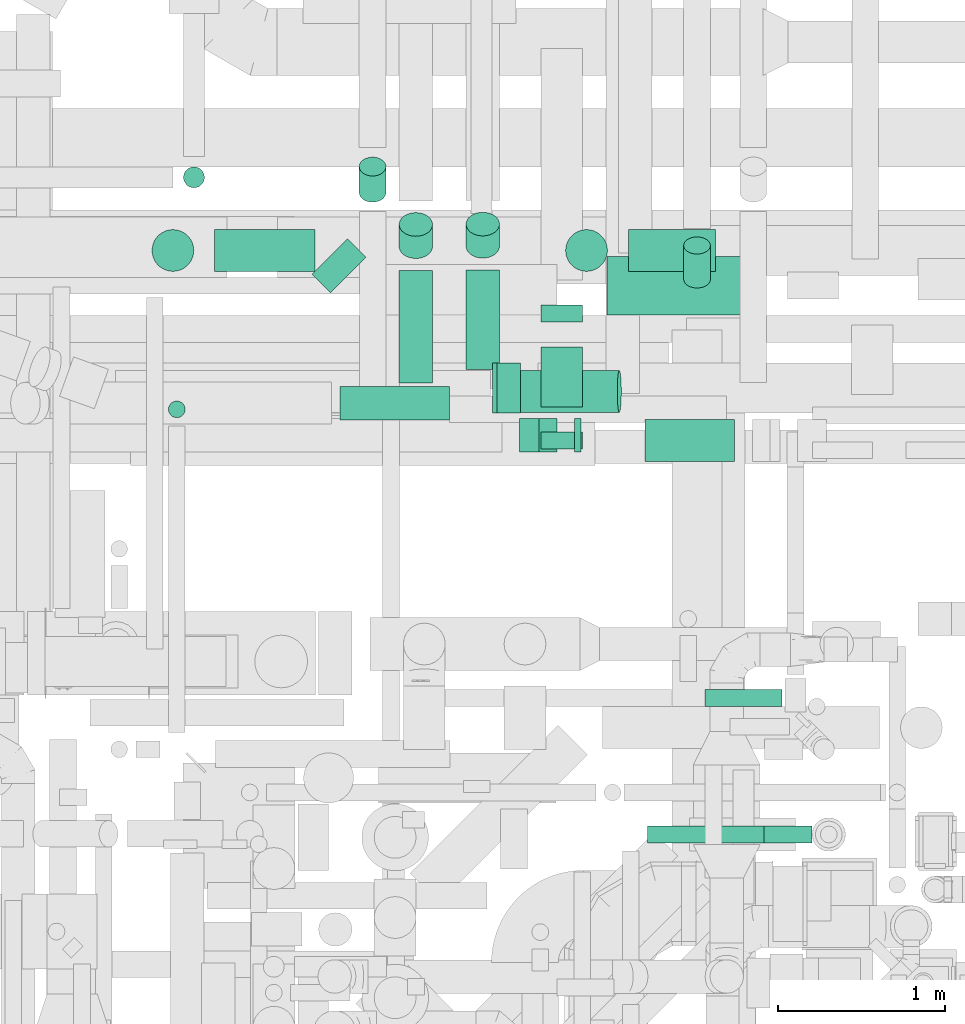
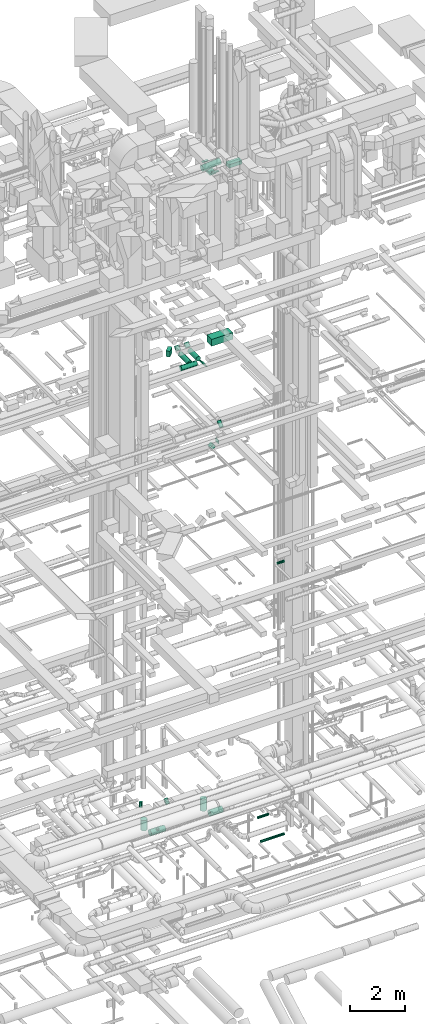
# One storey, part 248 of 337: 26 flow segments.
"""IFC2X3 building model written with IfcOpenShell, lengths in millimetres."""

import ifcopenshell
import ifcopenshell.guid

model = None  # the IFC model being written
_history = None  # IfcOwnerHistory: only IFC2X3 demands one
_inside = {}  # id of a spatial element -> (the spatial element, [elements in it])
_under = {}  # id of a project, library or spatial element -> (it, [spatial elements below it])
_declared = {}  # id of a project -> (the project, [libraries it declares])
_typed = {}  # id of a type object -> (the type object, [elements of that type])
_made_of = {}  # id of a material, layer set ... -> (it, [elements and type objects made of it])


def new_model(schema):
    """Start an empty IFC model of exactly this schema.

    Asked for "IFC4X3", IfcOpenShell would pick the latest addendum, in which some entities
    have other attributes; the version numbers below select the first issue.
    IFC2X3 requires an IfcOwnerHistory on every rooted entity: one is made here for all.
    """
    global model, _history
    if schema == "IFC4X3":
        model = ifcopenshell.file(schema_version=(4, 3, 0, 0))
    else:
        model = ifcopenshell.file(schema=schema)
    _inside.clear()
    _under.clear()
    _declared.clear()
    _typed.clear()
    _made_of.clear()
    _history = None
    if model.schema == "IFC2X3":
        org = make("IfcOrganization", Name="unknown")
        user = make(
            "IfcPersonAndOrganization",
            ThePerson=make("IfcPerson", FamilyName="unknown"),
            TheOrganization=org,
        )
        app = make(
            "IfcApplication",
            ApplicationDeveloper=org,
            Version="unknown",
            ApplicationFullName="unknown",
            ApplicationIdentifier="unknown",
        )
        _history = make(
            "IfcOwnerHistory",
            OwningUser=user,
            OwningApplication=app,
            ChangeAction="ADDED",
            CreationDate=0,
        )
    return model


def make(cls, **values):
    """One entity of the class cls with the attributes given. An attribute that is None is left unset."""
    return model.create_entity(
        cls, **{name: value for name, value in values.items() if value is not None}
    )


def entity(cls, *values):
    """Any entity or typed value of the class cls, its attributes in the order of the schema. None: left unset."""
    e = model.create_entity(cls)
    for i, value in enumerate(values):
        if value is not None:
            e[i] = value
    return e


def rooted(cls, **values):
    """An entity with a GlobalId (a new one), such as an element, a storey or a relation."""
    return make(cls, GlobalId=ifcopenshell.guid.new(), OwnerHistory=_history, **values)


def si_unit(unit_type, name, prefix=None):
    """IfcSIUnit, for example si_unit("LENGTHUNIT", "METRE", prefix="MILLI")."""
    return make("IfcSIUnit", UnitType=unit_type, Prefix=prefix, Name=name)


def converted_unit(unit_type, name, factor, base, dimensions=None, offset=None):
    """IfcConversionBasedUnit, such as the inch: factor (a typed value) times the base unit."""
    return make(
        "IfcConversionBasedUnit"
        if offset is None
        else "IfcConversionBasedUnitWithOffset",
        ConversionOffset=offset,
        Dimensions=None
        if dimensions is None
        else entity("IfcDimensionalExponents", *dimensions),
        UnitType=unit_type,
        Name=name,
        ConversionFactor=make(
            "IfcMeasureWithUnit", ValueComponent=factor, UnitComponent=base
        ),
    )


def derived_unit(unit_type, elements):
    """IfcDerivedUnit: a product of units, each with its exponent."""
    return make(
        "IfcDerivedUnit",
        Elements=[
            make("IfcDerivedUnitElement", Unit=unit, Exponent=power)
            for unit, power in elements
        ],
        UnitType=unit_type,
    )


def assignment(units):
    """IfcUnitAssignment: the units of a project."""
    return None if units is None else make("IfcUnitAssignment", Units=units)


def point(xyz):
    """IfcCartesianPoint."""
    return None if xyz is None else make("IfcCartesianPoint", Coordinates=xyz)


def direction(xyz):
    """IfcDirection."""
    return None if xyz is None else make("IfcDirection", DirectionRatios=xyz)


def frame(location, z_axis=None, x_axis=None):
    """IfcAxis2Placement3D, a coordinate frame: its origin and axes. An axis left out is left unset."""
    return make(
        "IfcAxis2Placement3D",
        Location=point(location),
        Axis=direction(z_axis),
        RefDirection=direction(x_axis),
    )


def frame_2d(location, x_axis=None):
    """IfcAxis2Placement2D, a coordinate frame in the plane: its origin and x axis."""
    return make(
        "IfcAxis2Placement2D", Location=point(location), RefDirection=direction(x_axis)
    )


def origin():
    """The frame at (0, 0, 0) with its axes left unset."""
    return frame((0.0, 0.0, 0.0))


def origin_2d_with_axis():
    """The frame at (0, 0) in the plane with the x axis (1, 0) written out."""
    return frame_2d((0.0, 0.0), x_axis=(1.0, 0.0))


def place(relative_to, where):
    """IfcLocalPlacement: puts the frame where relative to a parent placement (None: the world)."""
    return make(
        "IfcLocalPlacement", PlacementRelTo=relative_to, RelativePlacement=where
    )


def context(
    kind, dimensions, precision=None, world=None, true_north=None, identifier=None
):
    """IfcGeometricRepresentationContext, for example the 3D "Model" context."""
    return make(
        "IfcGeometricRepresentationContext",
        ContextIdentifier=identifier,
        ContextType=kind,
        CoordinateSpaceDimension=dimensions,
        Precision=precision,
        WorldCoordinateSystem=world,
        TrueNorth=true_north,
    )


def subcontext(parent, identifier, kind, view, scale=None):
    """IfcGeometricRepresentationSubContext, for example "Body" below "Model"."""
    return make(
        "IfcGeometricRepresentationSubContext",
        ContextIdentifier=identifier,
        ContextType=kind,
        ParentContext=parent,
        TargetScale=scale,
        TargetView=view,
    )


def project(units=None, contexts=None):
    """IfcProject with its units and contexts."""
    return rooted(
        "IfcProject",
        Name="project",
        RepresentationContexts=contexts,
        UnitsInContext=assignment(units),
    )


def spatial(cls, under=None, at=None, **own):
    """A site, building, storey or space (cls), placed at a placement, below another one or the project."""
    s = rooted(cls, ObjectPlacement=at, **own)
    if under is not None:
        _under.setdefault(under.id(), (under, []))[1].append(s)
    return s


def profile(cls, at=None, kind="AREA", **sizes):
    """A parametric profile (cls). Its sizes go by their IFC names, for example OverallWidth=200.0."""
    return make(cls, ProfileType=kind, Position=at, **sizes)


def rectangle(**sizes):
    """IfcRectangleProfileDef."""
    return profile("IfcRectangleProfileDef", **sizes)


def circle(**sizes):
    """IfcCircleProfileDef."""
    return profile("IfcCircleProfileDef", **sizes)


def extrude(swept, where, along, depth):
    """IfcExtrudedAreaSolid: the profile swept, set in the frame where, extruded along a direction by depth."""
    return make(
        "IfcExtrudedAreaSolid",
        SweptArea=swept,
        Position=where,
        ExtrudedDirection=direction(along),
        Depth=depth,
    )


def shape(context_of_items, identifier, shape_type, items):
    """IfcShapeRepresentation: the items that make up one representation, for example the "Body"."""
    return make(
        "IfcShapeRepresentation",
        ContextOfItems=context_of_items,
        RepresentationIdentifier=identifier,
        RepresentationType=shape_type,
        Items=items,
    )


def made_of(thing, what):
    """Note that an element or type object is made of a material, layer set ...; save() writes the relation."""
    if what is not None:
        _made_of.setdefault(what.id(), (what, []))[1].append(thing)
    return thing


def type_object(cls, material=None, **own):
    """A type object (cls), such as IfcWallType, which elements share."""
    return made_of(rooted(cls, **own), material)


def element(
    cls,
    number,
    at=None,
    inside=None,
    cuts=None,
    type_object=None,
    material=None,
    context=None,
    identifier="Body",
    shape_type=None,
    held_by="IfcProductDefinitionShape",
    body=None,
    shapes=None,
    **own,
):
    """One element of the class cls, such as IfcWall. Its Tag is "e" and its number.

    at: its placement. inside: the storey or other place that contains it. cuts: it is an
    opening in that element (IfcRelVoidsElement). A single representation is given by context,
    identifier, shape_type and body (its items); several are given by shapes. held_by: the class
    of the entity that holds the representations. save() writes the other relations.
    """
    e = rooted(cls, Tag="e%d" % number, ObjectPlacement=at, **own)
    if body is not None:
        shapes = [shape(context, identifier, shape_type, body)]
    if shapes is not None:
        e.Representation = make(held_by, Representations=shapes)
    if inside is not None:
        _inside.setdefault(inside.id(), (inside, []))[1].append(e)
    if cuts is not None:
        rooted(
            "IfcRelVoidsElement", RelatingBuildingElement=cuts, RelatedOpeningElement=e
        )
    if type_object is not None:
        _typed.setdefault(type_object.id(), (type_object, []))[1].append(e)
    return made_of(e, material)


def aggregate(whole, parts):
    """IfcRelAggregates: a whole, such as a stair, and the parts it consists of."""
    return rooted("IfcRelAggregates", RelatingObject=whole, RelatedObjects=parts)


def save(model, path):
    """Write the relations noted so far, then the file.

    IfcRelAggregates (storeys below a building ...), IfcRelContainedInSpatialStructure (elements
    in a storey), IfcRelDefinesByType, IfcRelAssociatesMaterial and IfcRelDeclares: one each for
    every whole, place, type object, material and project.
    """
    for whole, parts in _under.values():
        aggregate(whole, parts)
    for where, things in _inside.values():
        rooted(
            "IfcRelContainedInSpatialStructure",
            RelatedElements=things,
            RelatingStructure=where,
        )
    for kind, things in _typed.values():
        rooted("IfcRelDefinesByType", RelatedObjects=things, RelatingType=kind)
    for what, things in _made_of.values():
        rooted("IfcRelAssociatesMaterial", RelatedObjects=things, RelatingMaterial=what)
    for by, libraries in _declared.values():
        rooted("IfcRelDeclares", RelatingContext=by, RelatedDefinitions=libraries)
    model.write(path)


model = new_model("IFC2X3")

# Units and contexts
model_context = context("Model", 3, precision=0.01, world=origin(), true_north=direction((6.12303176911189e-17, 1.0)))
body_context = subcontext(model_context, "Body", "Model", "MODEL_VIEW")
ifc_project = project(units=[si_unit("LENGTHUNIT", "METRE", prefix="MILLI"), si_unit("AREAUNIT", "SQUARE_METRE"), si_unit("VOLUMEUNIT", "CUBIC_METRE"), converted_unit("PLANEANGLEUNIT", "DEGREE", entity("IfcRatioMeasure", 0.0174532925199433), si_unit("PLANEANGLEUNIT", "RADIAN"), dimensions=[0, 0, 0, 0, 0, 0, 0]), si_unit("MASSUNIT", "GRAM", prefix="KILO"), derived_unit("MASSDENSITYUNIT", [(si_unit("MASSUNIT", "GRAM", prefix="KILO"), 1), (si_unit("LENGTHUNIT", "METRE"), -3)]), derived_unit("MOMENTOFINERTIAUNIT", [(si_unit("LENGTHUNIT", "METRE"), 4)]), si_unit("TIMEUNIT", "SECOND"), si_unit("FREQUENCYUNIT", "HERTZ"), si_unit("THERMODYNAMICTEMPERATUREUNIT", "DEGREE_CELSIUS"), derived_unit("THERMALTRANSMITTANCEUNIT", [(si_unit("MASSUNIT", "GRAM", prefix="KILO"), 1), (si_unit("THERMODYNAMICTEMPERATUREUNIT", "KELVIN"), -1), (si_unit("TIMEUNIT", "SECOND"), -3)]), derived_unit("VOLUMETRICFLOWRATEUNIT", [(si_unit("LENGTHUNIT", "METRE"), 3), (si_unit("TIMEUNIT", "SECOND"), -1)]), derived_unit("MASSFLOWRATEUNIT", [(si_unit("MASSUNIT", "GRAM", prefix="KILO"), 1), (si_unit("TIMEUNIT", "SECOND"), -1)]), derived_unit("ROTATIONALFREQUENCYUNIT", [(si_unit("TIMEUNIT", "SECOND"), -1)]), si_unit("ELECTRICCURRENTUNIT", "AMPERE"), si_unit("ELECTRICVOLTAGEUNIT", "VOLT"), si_unit("POWERUNIT", "WATT"), si_unit("FORCEUNIT", "NEWTON", prefix="KILO"), si_unit("ILLUMINANCEUNIT", "LUX"), si_unit("LUMINOUSFLUXUNIT", "LUMEN"), si_unit("LUMINOUSINTENSITYUNIT", "CANDELA"), derived_unit("USERDEFINED", [(si_unit("MASSUNIT", "GRAM", prefix="KILO"), -1), (si_unit("LENGTHUNIT", "METRE"), -2), (si_unit("TIMEUNIT", "SECOND"), 3), (si_unit("LUMINOUSFLUXUNIT", "LUMEN"), 1)]), derived_unit("LINEARVELOCITYUNIT", [(si_unit("LENGTHUNIT", "METRE"), 1), (si_unit("TIMEUNIT", "SECOND"), -1)]), si_unit("PRESSUREUNIT", "PASCAL"), derived_unit("USERDEFINED", [(si_unit("LENGTHUNIT", "METRE"), -2), (si_unit("MASSUNIT", "GRAM", prefix="KILO"), 1), (si_unit("TIMEUNIT", "SECOND"), -2)]), derived_unit("LINEARFORCEUNIT", [(si_unit("MASSUNIT", "GRAM", prefix="KILO"), 1), (si_unit("LENGTHUNIT", "METRE"), 1), (si_unit("TIMEUNIT", "SECOND"), -2), (si_unit("LENGTHUNIT", "METRE"), -1)]), derived_unit("PLANARFORCEUNIT", [(si_unit("MASSUNIT", "GRAM", prefix="KILO"), 1), (si_unit("LENGTHUNIT", "METRE"), 1), (si_unit("TIMEUNIT", "SECOND"), -2), (si_unit("LENGTHUNIT", "METRE"), -2)])], contexts=[model_context])

# Site, building, storey
site_placement = place(None, origin())
site = spatial("IfcSite", under=ifc_project, at=site_placement, CompositionType="ELEMENT")
building_placement = place(site_placement, origin())
building = spatial("IfcBuilding", under=site, at=building_placement, CompositionType="ELEMENT")
storey_placement = place(building_placement, origin())
storey = spatial("IfcBuildingStorey", under=building, at=storey_placement, CompositionType="ELEMENT", Elevation=0.0)

# Flow segments
duct_segment_type_1 = type_object("IfcDuctSegmentType", PredefinedType="NOTDEFINED")
flow_segment_1_placement = place(storey_placement, frame((55823.14, 15096.14, 19059.58)))
element("IfcFlowSegment", 1, at=flow_segment_1_placement, inside=storey, type_object=duct_segment_type_1, context=body_context, shape_type="SweptSolid", body=[
    extrude(rectangle(XDim=157.808294781249, YDim=300.000000000002, at=origin_2d_with_axis()), frame((161.86, 161.86, 0.0), z_axis=(0.0, 0.0, 1.0), x_axis=(-0.707106781186527, 0.707106781186568, 0.0)), (0.0, 0.0, 1.0), 249.999999999999),
])
flow_segment_2_placement = place(storey_placement, frame((56902.44, 14375.32, 18679.52)))
element("IfcFlowSegment", 2, at=flow_segment_2_placement, inside=storey, type_object=duct_segment_type_1, context=body_context, shape_type="SweptSolid", body=[
    extrude(rectangle(XDim=37.5378797540777, YDim=199.999999999998, at=origin_2d_with_axis()), frame((83.98, 0.0, 83.98), z_axis=(0.0, 1.0, 0.0), x_axis=(0.707106781186346, 0.0, 0.70710678118675)), (0.0, 0.0, 1.0), 299.999999999999),
])
flow_segment_3_placement = place(storey_placement, frame((57589.44, 14964.34, 19034.58)))
element("IfcFlowSegment", 3, at=flow_segment_3_placement, inside=storey, type_object=duct_segment_type_1, context=body_context, shape_type="SweptSolid", body=[
    extrude(rectangle(XDim=880.000000000086, YDim=350.000000000001, at=origin_2d_with_axis()), frame((440.0, 175.0, 0.0)), (0.0, 0.0, 1.0), 300.000000000001),
])
flow_segment_4_placement = place(storey_placement, frame((57395.07, 14143.91, 15300.0)))
element("IfcFlowSegment", 4, at=flow_segment_4_placement, inside=storey, type_object=duct_segment_type_1, context=body_context, shape_type="SweptSolid", body=[
    extrude(rectangle(XDim=37.5219564660659, YDim=200.0, at=origin_2d_with_axis()), frame((18.76, 100.0, 0.0), z_axis=(0.0, 0.0, 1.0), x_axis=(-1.0, 0.0, 0.0)), (0.0, 0.0, 1.0), 150.000000000001),
])
flow_segment_5_placement = place(storey_placement, frame((57064.74, 14143.91, 15137.87)))
element("IfcFlowSegment", 5, at=flow_segment_5_placement, inside=storey, type_object=duct_segment_type_1, context=body_context, shape_type="SweptSolid", body=[
    extrude(rectangle(XDim=167.157287525415, YDim=150.000000000004, at=origin_2d_with_axis()), frame((112.13, 0.0, 112.13), z_axis=(0.0, 1.0, 0.0), x_axis=(-0.707106781186535, 0.0, -0.707106781186561)), (0.0, 0.0, 1.0), 200.000000000002),
])
flow_segment_6_placement = place(storey_placement, frame((57815.82, 14087.02, 27325.0)))
element("IfcFlowSegment", 6, at=flow_segment_6_placement, inside=storey, type_object=duct_segment_type_1, context=body_context, shape_type="SweptSolid", body=[
    extrude(rectangle(XDim=536.801948466038, YDim=249.999999999999, at=origin_2d_with_axis()), frame((268.4, 125.0, 0.0)), (0.0, 0.0, 1.0), 150.000000000001),
])
flow_segment_7_placement = place(storey_placement, frame((57192.89, 14922.02, 27270.0)))
element("IfcFlowSegment", 7, at=flow_segment_7_placement, inside=storey, type_object=duct_segment_type_1, context=body_context, shape_type="SweptSolid", body=[
    extrude(rectangle(XDim=99.9999999999989, YDim=250.000000000004, at=origin_2d_with_axis()), frame((125.0, 50.0, 0.0), z_axis=(0.0, 0.0, 1.0), x_axis=(0.0, 1.0, 0.0)), (0.0, 0.0, 1.0), 30.0000000000278),
])
flow_segment_8_placement = place(storey_placement, frame((57192.89, 14412.02, 27020.0)))
element("IfcFlowSegment", 8, at=flow_segment_8_placement, inside=storey, type_object=duct_segment_type_1, context=body_context, shape_type="SweptSolid", body=[
    extrude(rectangle(XDim=360.000000000018, YDim=250.000000000004, at=origin_2d_with_axis()), frame((125.0, 180.0, 0.0), z_axis=(0.0, 0.0, 1.0), x_axis=(0.0, -1.0, 0.0)), (0.0, 0.0, 1.0), 100.000000000003),
])
flow_segment_9_placement = place(storey_placement, frame((57192.89, 14162.02, 27270.0)))
element("IfcFlowSegment", 9, at=flow_segment_9_placement, inside=storey, type_object=duct_segment_type_1, context=body_context, shape_type="SweptSolid", body=[
    extrude(rectangle(XDim=249.999999999995, YDim=100.000000000001, at=origin_2d_with_axis()), frame((125.0, 50.0, 0.0), z_axis=(0.0, 0.0, 1.0), x_axis=(-1.0, 0.0, 0.0)), (0.0, 0.0, 1.0), 10.0000000000064),
])
duct_segment_type_2 = type_object("IfcDuctSegmentType", PredefinedType="NOTDEFINED")
flow_segment_10_placement = place(storey_placement, frame((54864.2, 15222.36, -1530.0)))
element("IfcFlowSegment", 10, at=flow_segment_10_placement, inside=storey, type_object=duct_segment_type_2, context=body_context, shape_type="SweptSolid", body=[
    extrude(circle(Radius=125.0, at=origin_2d_with_axis()), frame((126.6, 126.6, 0.0), z_axis=(0.0, 0.0, 1.0), x_axis=(-1.0, 0.0, 0.0)), (0.0, 0.0, 1.0), 460.000024999991),
])
flow_segment_11_placement = place(storey_placement, frame((55240.79, 15222.36, -1906.6)))
element("IfcFlowSegment", 11, at=flow_segment_11_placement, inside=storey, type_object=duct_segment_type_2, context=body_context, shape_type="SweptSolid", body=[
    extrude(circle(Radius=125.0, at=origin_2d_with_axis()), frame((0.0, 126.6, 126.6), z_axis=(1.0, 0.0, 0.0), x_axis=(0.0, -1.0, 0.0)), (0.0, 0.0, 1.0), 599.999999999968),
])
flow_segment_12_placement = place(storey_placement, frame((57339.23, 15222.36, -1530.0)))
element("IfcFlowSegment", 12, at=flow_segment_12_placement, inside=storey, type_object=duct_segment_type_2, context=body_context, shape_type="SweptSolid", body=[
    extrude(circle(Radius=125.0, at=origin_2d_with_axis()), frame((126.6, 126.6, 0.0), z_axis=(0.0, 0.0, 1.0), x_axis=(-1.0, 0.0, 0.0)), (0.0, 0.0, 1.0), 510.000025000003),
])
flow_segment_13_placement = place(storey_placement, frame((57715.82, 15222.36, -1906.6)))
element("IfcFlowSegment", 13, at=flow_segment_13_placement, inside=storey, type_object=duct_segment_type_2, context=body_context, shape_type="SweptSolid", body=[
    extrude(circle(Radius=125.0, at=origin_2d_with_axis()), frame((0.0, 126.6, 126.6), z_axis=(1.0, 0.0, 0.0), x_axis=(0.0, -1.0, 0.0)), (0.0, 0.0, 1.0), 522.039199965924),
])
flow_segment_14_placement = place(storey_placement, frame((57831.35, 11802.63, -1001.6)))
element("IfcFlowSegment", 14, at=flow_segment_14_placement, inside=storey, type_object=duct_segment_type_2, context=body_context, shape_type="SweptSolid", body=[
    extrude(circle(Radius=50.0, at=origin_2d_with_axis()), frame((0.0, 51.6, 51.6), z_axis=(1.0, 0.0, 0.0), x_axis=(0.0, 1.0, 0.0)), (0.0, 0.0, 1.0), 984.281258610277),
])
flow_segment_15_placement = place(storey_placement, frame((58174.2, 12619.48, -571.6)))
element("IfcFlowSegment", 15, at=flow_segment_15_placement, inside=storey, type_object=duct_segment_type_2, context=body_context, shape_type="SweptSolid", body=[
    extrude(circle(Radius=50.0, at=origin_2d_with_axis()), frame((0.0, 51.6, 51.6), z_axis=(1.0, 0.0, 0.0), x_axis=(0.0, -1.0, 0.0)), (0.0, 0.0, 1.0), 459.925609999933),
])
flow_segment_16_placement = place(storey_placement, frame((55052.5, 15722.62, -875.0)))
element("IfcFlowSegment", 16, at=flow_segment_16_placement, inside=storey, type_object=duct_segment_type_2, context=body_context, shape_type="SweptSolid", body=[
    extrude(circle(Radius=62.5, at=origin_2d_with_axis()), frame((64.1, 64.1, 0.0), z_axis=(0.0, 0.0, 1.0), x_axis=(0.0, 1.0, 0.0)), (0.0, 0.0, 1.0), 240.000000000007),
])
flow_segment_17_placement = place(storey_placement, frame((58527.28, 11802.63, 10998.4)))
element("IfcFlowSegment", 17, at=flow_segment_17_placement, inside=storey, type_object=duct_segment_type_2, context=body_context, shape_type="SweptSolid", body=[
    extrude(circle(Radius=50.0, at=origin_2d_with_axis()), frame((0.0, 51.6, 51.6), z_axis=(1.0, 0.0, 0.0), x_axis=(0.0, -1.0, 0.0)), (0.0, 0.0, 1.0), 288.353075250248),
])
flow_segment_18_placement = place(storey_placement, frame((55990.04, 14333.92, 18848.4)))
element("IfcFlowSegment", 18, at=flow_segment_18_placement, inside=storey, type_object=duct_segment_type_2, context=body_context, shape_type="SweptSolid", body=[
    extrude(circle(Radius=100.0, at=origin_2d_with_axis()), frame((0.0, 101.6, 101.6), z_axis=(1.0, 0.0, 0.0), x_axis=(0.0, 1.0, 0.0)), (0.0, 0.0, 1.0), 654.999999999964),
])
flow_segment_19_placement = place(storey_placement, frame((56342.71, 15299.63, 18936.27)))
element("IfcFlowSegment", 19, at=flow_segment_19_placement, inside=storey, type_object=duct_segment_type_2, context=body_context, shape_type="SweptSolid", body=[
    extrude(circle(Radius=100.0, at=origin_2d_with_axis()), frame((101.6, 72.31, 72.31), z_axis=(0.0, 0.707106781186544, 0.707106781186551), x_axis=(-1.0, 0.0, 0.0)), (0.0, 0.0, 1.0), 187.867965644027),
])
flow_segment_20_placement = place(storey_placement, frame((56342.71, 14555.52, 18848.4)))
element("IfcFlowSegment", 20, at=flow_segment_20_placement, inside=storey, type_object=duct_segment_type_2, context=body_context, shape_type="SweptSolid", body=[
    extrude(circle(Radius=100.0, at=origin_2d_with_axis()), frame((101.6, 0.0, 101.6), z_axis=(0.0, 1.0, 0.0), x_axis=(-1.0, 0.0, 0.0)), (0.0, 0.0, 1.0), 675.000000000007),
])
flow_segment_21_placement = place(storey_placement, frame((56743.44, 15301.79, 18936.27)))
element("IfcFlowSegment", 21, at=flow_segment_21_placement, inside=storey, type_object=duct_segment_type_2, context=body_context, shape_type="SweptSolid", body=[
    extrude(circle(Radius=100.0, at=origin_2d_with_axis()), frame((101.6, 72.31, 72.31), z_axis=(0.0, 0.707106781186548, 0.707106781186548), x_axis=(-1.0, 0.0, 0.0)), (0.0, 0.0, 1.0), 187.867965644036),
])
flow_segment_22_placement = place(storey_placement, frame((56743.44, 14635.52, 18848.4)))
element("IfcFlowSegment", 22, at=flow_segment_22_placement, inside=storey, type_object=duct_segment_type_2, context=body_context, shape_type="SweptSolid", body=[
    extrude(circle(Radius=100.0, at=origin_2d_with_axis()), frame((101.6, 0.0, 101.6), z_axis=(0.0, 1.0, 0.0), x_axis=(1.0, 0.0, 0.0)), (0.0, 0.0, 1.0), 597.157287525392),
])
flow_segment_23_placement = place(storey_placement, frame((58045.69, 15122.92, 15099.55)))
element("IfcFlowSegment", 23, at=flow_segment_23_placement, inside=storey, type_object=duct_segment_type_2, context=body_context, shape_type="SweptSolid", body=[
    extrude(circle(Radius=80.0, at=origin_2d_with_axis()), frame((81.6, 53.02, 62.88), z_axis=(0.0, 0.766044443118978, 0.642787609686539), x_axis=(-1.0, 0.0, 0.0)), (0.0, 0.0, 1.0), 264.681862615612),
])
flow_segment_24_placement = place(storey_placement, frame((56901.92, 14378.71, 27250.17)))
element("IfcFlowSegment", 24, at=flow_segment_24_placement, inside=storey, type_object=duct_segment_type_2, context=body_context, shape_type="SweptSolid", body=[
    extrude(circle(Radius=125.0, at=origin_2d_with_axis()), frame((13.71, 126.6, 126.01), z_axis=(0.995295276100978, 0.0, 0.0968881487648383), x_axis=(0.0, -1.0, 0.0)), (0.0, 0.0, 1.0), 749.809331446809),
])
flow_segment_25_placement = place(storey_placement, frame((54962.63, 14346.8, -980.0)))
element("IfcFlowSegment", 25, at=flow_segment_25_placement, inside=storey, type_object=duct_segment_type_2, context=body_context, shape_type="SweptSolid", body=[
    extrude(circle(Radius=50.0, at=origin_2d_with_axis()), frame((51.6, 51.6, 0.0), z_axis=(0.0, 0.0, 1.0), x_axis=(-1.0, 0.0, 0.0)), (0.0, 0.0, 1.0), 29.9999750000201),
])
flow_segment_26_placement = place(storey_placement, frame((56103.94, 15636.58, -1111.3)))
element("IfcFlowSegment", 26, at=flow_segment_26_placement, inside=storey, type_object=duct_segment_type_2, context=body_context, shape_type="SweptSolid", body=[
    extrude(circle(Radius=80.0, at=origin_2d_with_axis()), frame((81.6, 58.16, 58.16), z_axis=(0.0, 0.707106781186487, 0.707106781186608), x_axis=(-1.0, 0.0, 0.0)), (0.0, 0.0, 1.0), 221.005029960366),
])

save(model, "model.ifc")
